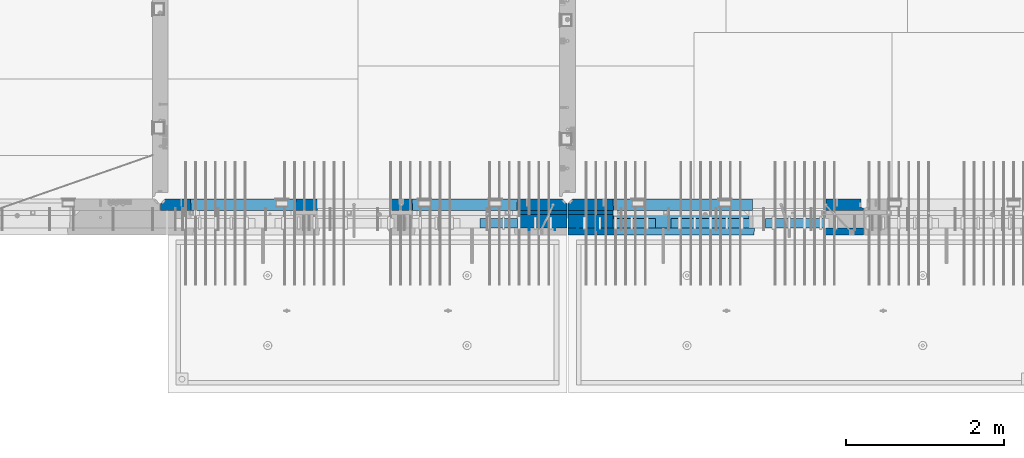
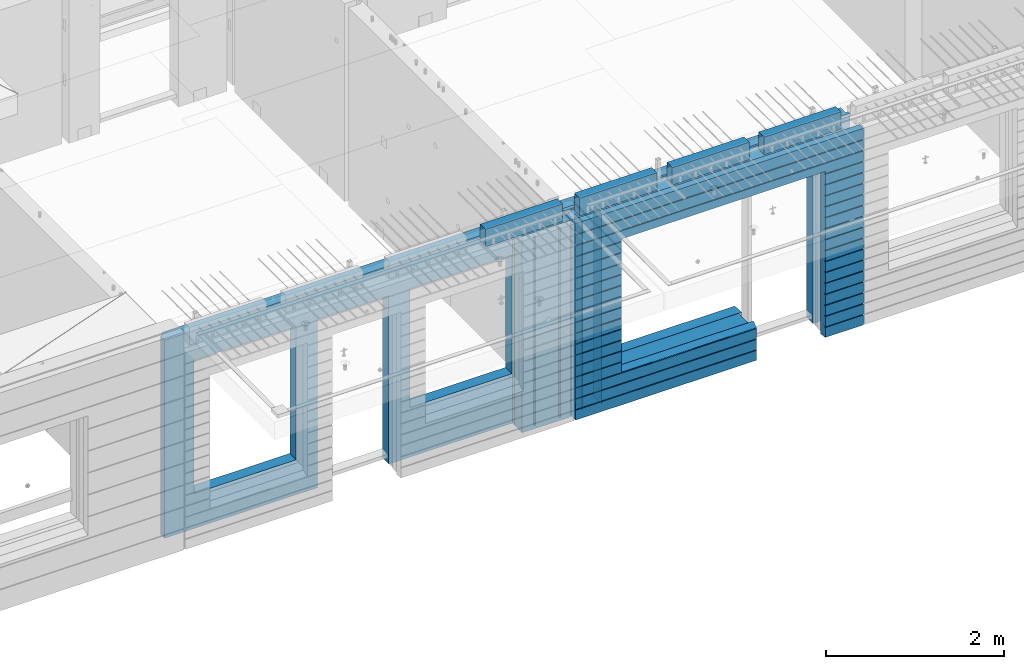
# One storey, part 223 of 341: 16 walls, 8 elements without a shape of their own.
"""IFC2X3 building model written with IfcOpenShell, lengths in millimetres."""

import ifcopenshell
import ifcopenshell.guid

model = None  # the IFC model being written
_history = None  # IfcOwnerHistory: only IFC2X3 demands one
_inside = {}  # id of a spatial element -> (the spatial element, [elements in it])
_under = {}  # id of a project, library or spatial element -> (it, [spatial elements below it])
_declared = {}  # id of a project -> (the project, [libraries it declares])
_typed = {}  # id of a type object -> (the type object, [elements of that type])
_made_of = {}  # id of a material, layer set ... -> (it, [elements and type objects made of it])


def new_model(schema):
    """Start an empty IFC model of exactly this schema.

    Asked for "IFC4X3", IfcOpenShell would pick the latest addendum, in which some entities
    have other attributes; the version numbers below select the first issue.
    IFC2X3 requires an IfcOwnerHistory on every rooted entity: one is made here for all.
    """
    global model, _history
    if schema == "IFC4X3":
        model = ifcopenshell.file(schema_version=(4, 3, 0, 0))
    else:
        model = ifcopenshell.file(schema=schema)
    _inside.clear()
    _under.clear()
    _declared.clear()
    _typed.clear()
    _made_of.clear()
    _history = None
    if model.schema == "IFC2X3":
        org = make("IfcOrganization", Name="unknown")
        user = make(
            "IfcPersonAndOrganization",
            ThePerson=make("IfcPerson", FamilyName="unknown"),
            TheOrganization=org,
        )
        app = make(
            "IfcApplication",
            ApplicationDeveloper=org,
            Version="unknown",
            ApplicationFullName="unknown",
            ApplicationIdentifier="unknown",
        )
        _history = make(
            "IfcOwnerHistory",
            OwningUser=user,
            OwningApplication=app,
            ChangeAction="ADDED",
            CreationDate=0,
        )
    return model


def make(cls, **values):
    """One entity of the class cls with the attributes given. An attribute that is None is left unset."""
    return model.create_entity(
        cls, **{name: value for name, value in values.items() if value is not None}
    )


def rooted(cls, **values):
    """An entity with a GlobalId (a new one), such as an element, a storey or a relation."""
    return make(cls, GlobalId=ifcopenshell.guid.new(), OwnerHistory=_history, **values)


def si_unit(unit_type, name, prefix=None):
    """IfcSIUnit, for example si_unit("LENGTHUNIT", "METRE", prefix="MILLI")."""
    return make("IfcSIUnit", UnitType=unit_type, Prefix=prefix, Name=name)


def assignment(units):
    """IfcUnitAssignment: the units of a project."""
    return None if units is None else make("IfcUnitAssignment", Units=units)


def point(xyz):
    """IfcCartesianPoint."""
    return None if xyz is None else make("IfcCartesianPoint", Coordinates=xyz)


def direction(xyz):
    """IfcDirection."""
    return None if xyz is None else make("IfcDirection", DirectionRatios=xyz)


def frame(location, z_axis=None, x_axis=None):
    """IfcAxis2Placement3D, a coordinate frame: its origin and axes. An axis left out is left unset."""
    return make(
        "IfcAxis2Placement3D",
        Location=point(location),
        Axis=direction(z_axis),
        RefDirection=direction(x_axis),
    )


def origin_with_axes():
    """The frame at (0, 0, 0) with the z axis (0, 0, 1) and the x axis (1, 0, 0) written out."""
    return frame((0.0, 0.0, 0.0), z_axis=(0.0, 0.0, 1.0), x_axis=(1.0, 0.0, 0.0))


def place(relative_to, where):
    """IfcLocalPlacement: puts the frame where relative to a parent placement (None: the world)."""
    return make(
        "IfcLocalPlacement", PlacementRelTo=relative_to, RelativePlacement=where
    )


def context(
    kind, dimensions, precision=None, world=None, true_north=None, identifier=None
):
    """IfcGeometricRepresentationContext, for example the 3D "Model" context."""
    return make(
        "IfcGeometricRepresentationContext",
        ContextIdentifier=identifier,
        ContextType=kind,
        CoordinateSpaceDimension=dimensions,
        Precision=precision,
        WorldCoordinateSystem=world,
        TrueNorth=true_north,
    )


def subcontext(parent, identifier, kind, view, scale=None):
    """IfcGeometricRepresentationSubContext, for example "Body" below "Model"."""
    return make(
        "IfcGeometricRepresentationSubContext",
        ContextIdentifier=identifier,
        ContextType=kind,
        ParentContext=parent,
        TargetScale=scale,
        TargetView=view,
    )


def project(units=None, contexts=None):
    """IfcProject with its units and contexts."""
    return rooted(
        "IfcProject",
        Name="project",
        RepresentationContexts=contexts,
        UnitsInContext=assignment(units),
    )


def spatial(cls, under=None, at=None, **own):
    """A site, building, storey or space (cls), placed at a placement, below another one or the project."""
    s = rooted(cls, ObjectPlacement=at, **own)
    if under is not None:
        _under.setdefault(under.id(), (under, []))[1].append(s)
    return s


def faces_of(points, faces, orient=None, outer=None):
    """IfcFace entities. A face is a list of loops; a loop is a list of indices into points, from 0.

    orient and outer hold one flag for each loop. By default every Orientation is true, the
    first loop of a face is its IfcFaceOuterBound and the others are IfcFaceBound.
    """
    made = []
    for i, loops in enumerate(faces):
        bounds = []
        for j, loop in enumerate(loops):
            is_outer = j == 0 if outer is None else outer[i][j]
            bounds.append(
                make(
                    "IfcFaceOuterBound" if is_outer else "IfcFaceBound",
                    Bound=make("IfcPolyLoop", Polygon=[points[k] for k in loop]),
                    Orientation=True if orient is None else orient[i][j],
                )
            )
        made.append(make("IfcFace", Bounds=bounds))
    return made


def faceted_brep(points, faces, orient=None, outer=None, voids=None):
    """IfcFacetedBrep: a solid bounded by flat faces; with voids (closed shells), ...WithVoids."""
    shared = [point(p) for p in points]
    hull = make("IfcClosedShell", CfsFaces=faces_of(shared, faces, orient, outer))
    if voids is None:
        return make("IfcFacetedBrep", Outer=hull)
    return make(
        "IfcFacetedBrepWithVoids",
        Outer=hull,
        Voids=[
            make(cls, CfsFaces=faces_of(shared, fs, o, b)) for cls, fs, o, b in voids
        ],
    )


def shape(context_of_items, identifier, shape_type, items):
    """IfcShapeRepresentation: the items that make up one representation, for example the "Body"."""
    return make(
        "IfcShapeRepresentation",
        ContextOfItems=context_of_items,
        RepresentationIdentifier=identifier,
        RepresentationType=shape_type,
        Items=items,
    )


def material(Name=None, Category=None):
    """IfcMaterial."""
    return make("IfcMaterial", Name=Name, Category=Category)


def made_of(thing, what):
    """Note that an element or type object is made of a material, layer set ...; save() writes the relation."""
    if what is not None:
        _made_of.setdefault(what.id(), (what, []))[1].append(thing)
    return thing


def type_object(cls, material=None, **own):
    """A type object (cls), such as IfcWallType, which elements share."""
    return made_of(rooted(cls, **own), material)


def element(
    cls,
    number,
    at=None,
    inside=None,
    cuts=None,
    type_object=None,
    material=None,
    context=None,
    identifier="Body",
    shape_type=None,
    held_by="IfcProductDefinitionShape",
    body=None,
    shapes=None,
    **own,
):
    """One element of the class cls, such as IfcWall. Its Tag is "e" and its number.

    at: its placement. inside: the storey or other place that contains it. cuts: it is an
    opening in that element (IfcRelVoidsElement). A single representation is given by context,
    identifier, shape_type and body (its items); several are given by shapes. held_by: the class
    of the entity that holds the representations. save() writes the other relations.
    """
    e = rooted(cls, Tag="e%d" % number, ObjectPlacement=at, **own)
    if body is not None:
        shapes = [shape(context, identifier, shape_type, body)]
    if shapes is not None:
        e.Representation = make(held_by, Representations=shapes)
    if inside is not None:
        _inside.setdefault(inside.id(), (inside, []))[1].append(e)
    if cuts is not None:
        rooted(
            "IfcRelVoidsElement", RelatingBuildingElement=cuts, RelatedOpeningElement=e
        )
    if type_object is not None:
        _typed.setdefault(type_object.id(), (type_object, []))[1].append(e)
    return made_of(e, material)


def aggregate(whole, parts):
    """IfcRelAggregates: a whole, such as a stair, and the parts it consists of."""
    return rooted("IfcRelAggregates", RelatingObject=whole, RelatedObjects=parts)


def save(model, path):
    """Write the relations noted so far, then the file.

    IfcRelAggregates (storeys below a building ...), IfcRelContainedInSpatialStructure (elements
    in a storey), IfcRelDefinesByType, IfcRelAssociatesMaterial and IfcRelDeclares: one each for
    every whole, place, type object, material and project.
    """
    for whole, parts in _under.values():
        aggregate(whole, parts)
    for where, things in _inside.values():
        rooted(
            "IfcRelContainedInSpatialStructure",
            RelatedElements=things,
            RelatingStructure=where,
        )
    for kind, things in _typed.values():
        rooted("IfcRelDefinesByType", RelatedObjects=things, RelatingType=kind)
    for what, things in _made_of.values():
        rooted("IfcRelAssociatesMaterial", RelatedObjects=things, RelatingMaterial=what)
    for by, libraries in _declared.values():
        rooted("IfcRelDeclares", RelatingContext=by, RelatedDefinitions=libraries)
    model.write(path)


model = new_model("IFC2X3")

# Units and contexts
model_context = context("Model", 3, precision=1e-05, world=origin_with_axes())
body_context = subcontext(model_context, "Body", "Model", "MODEL_VIEW")
ifc_project = project(units=[si_unit("LENGTHUNIT", "METRE", prefix="MILLI"), si_unit("AREAUNIT", "SQUARE_METRE"), si_unit("VOLUMEUNIT", "CUBIC_METRE"), si_unit("MASSUNIT", "GRAM", prefix="KILO"), si_unit("TIMEUNIT", "SECOND"), si_unit("PLANEANGLEUNIT", "RADIAN"), si_unit("SOLIDANGLEUNIT", "STERADIAN"), si_unit("THERMODYNAMICTEMPERATUREUNIT", "DEGREE_CELSIUS"), si_unit("LUMINOUSINTENSITYUNIT", "LUMEN")], contexts=[model_context])

# Site, building, storey
site_placement = place(None, origin_with_axes())
site = spatial("IfcSite", under=ifc_project, at=site_placement, CompositionType="ELEMENT")
building_placement = place(site_placement, origin_with_axes())
building = spatial("IfcBuilding", under=site, at=building_placement, CompositionType="ELEMENT")
storey_placement = place(building_placement, origin_with_axes())
storey = spatial("IfcBuildingStorey", under=building, at=storey_placement, Name="5", CompositionType="ELEMENT", Elevation=0.0)

# Assembly, walls
assembly_1_placement = place(storey_placement, origin_with_axes())
assembly_1 = element("IfcElementAssembly", 1, at=assembly_1_placement, inside=storey, AssemblyPlace="NOTDEFINED", PredefinedType="REINFORCEMENT_UNIT")
ifc_material_1 = material(Name="Undefined")
wall_type_1 = type_object("IfcWallType", PredefinedType="NOTDEFINED")
wall_1_placement = place(assembly_1_placement, frame((21325.0, 7780.0, 95115.0), z_axis=(0.0, 0.0, 1.0), x_axis=(0.0, -1.0, 0.0)))
wall_1 = element("IfcWall", 2, at=wall_1_placement, type_object=wall_type_1, material=ifc_material_1, Name="(PD)", context=body_context, shape_type="Brep", body=[
    faceted_brep([(0.0, 5.0, -1300.0), (0.0, 5.0, 1300.0), (180.0, 5.0, 1300.0), (180.0, 5.0, -1300.0), (0.0, -5.0, 1300.0), (180.0, -5.0, 1300.0), (0.0, -5.0, -1300.0), (180.0, -5.0, -1300.0)], [[[0, 1, 2, 3]], [[1, 4, 5, 2]], [[4, 6, 7, 5]], [[6, 0, 3, 7]], [[5, 7, 3, 2]], [[6, 4, 1, 0]]]),
])
wall_2_placement = place(assembly_1_placement, frame((21650.0, 7780.0, 95115.0), z_axis=(0.0, 0.0, 1.0), x_axis=(0.0, -1.0, 0.0)))
wall_2 = element("IfcWall", 3, at=wall_2_placement, type_object=wall_type_1, material=ifc_material_1, Name="(PD)", context=body_context, shape_type="Brep", body=[
    faceted_brep([(0.0, 5.0, -1300.0), (0.0, 5.0, 1300.0), (180.0, 5.0, 1300.0), (180.0, 5.0, -1300.0), (0.0, -5.0, 1300.0), (180.0, -5.0, 1300.0), (0.0, -5.0, -1300.0), (180.0, -5.0, -1300.0)], [[[0, 1, 2, 3]], [[1, 4, 5, 2]], [[4, 6, 7, 5]], [[6, 0, 3, 7]], [[5, 7, 3, 2]], [[6, 4, 1, 0]]]),
])

assembly_2_placement = place(storey_placement, origin_with_axes())
assembly_2 = element("IfcElementAssembly", 4, at=assembly_2_placement, inside=storey, AssemblyPlace="NOTDEFINED", PredefinedType="REINFORCEMENT_UNIT")
wall_3_placement = place(assembly_2_placement, frame((22190.0, 7780.0, 95115.0), z_axis=(0.0, 0.0, 1.0), x_axis=(0.0, -1.0, 0.0)))
wall_3 = element("IfcWall", 5, at=wall_3_placement, type_object=wall_type_1, material=ifc_material_1, Name="(PD)", context=body_context, shape_type="Brep", body=[
    faceted_brep([(0.0, 5.0, -1300.0), (0.0, 5.0, 1300.0), (180.0, 5.0, 1300.0), (180.0, 5.0, -1300.0), (0.0, -5.0, 1300.0), (180.0, -5.0, 1300.0), (0.0, -5.0, -1300.0), (180.0, -5.0, -1300.0)], [[[0, 1, 2, 3]], [[1, 4, 5, 2]], [[4, 6, 7, 5]], [[6, 0, 3, 7]], [[5, 7, 3, 2]], [[6, 4, 1, 0]]]),
])
wall_4_placement = place(assembly_2_placement, frame((21940.0, 7780.0, 95115.0), z_axis=(0.0, 0.0, 1.0), x_axis=(0.0, -1.0, 0.0)))
wall_4 = element("IfcWall", 6, at=wall_4_placement, type_object=wall_type_1, material=ifc_material_1, Name="(PD)", context=body_context, shape_type="Brep", body=[
    faceted_brep([(0.0, 5.0, -1300.0), (0.0, 5.0, 1300.0), (180.0, 5.0, 1300.0), (180.0, 5.0, -1300.0), (0.0, -5.0, 1300.0), (180.0, -5.0, 1300.0), (0.0, -5.0, -1300.0), (180.0, -5.0, -1300.0)], [[[0, 1, 2, 3]], [[1, 4, 5, 2]], [[4, 6, 7, 5]], [[6, 0, 3, 7]], [[5, 7, 3, 2]], [[6, 4, 1, 0]]]),
])

# Assemblies, wall
assembly_3_placement = place(storey_placement, origin_with_axes())
assembly_3 = element("IfcElementAssembly", 7, at=assembly_3_placement, inside=storey, AssemblyPlace="NOTDEFINED", PredefinedType="REINFORCEMENT_UNIT")
assembly_4_placement = place(assembly_3_placement, origin_with_axes())
assembly_4 = element("IfcElementAssembly", 8, at=assembly_4_placement, Name="Steel Assembly", AssemblyPlace="NOTDEFINED", PredefinedType="NOTDEFINED")
aggregate(assembly_3, [assembly_4])
ifc_material_2 = material()
wall_type_2 = type_object("IfcWallType", PredefinedType="NOTDEFINED")
wall_5_placement = place(assembly_4_placement, frame((20699.9998568133, 7690.00021946163, 96590.0), z_axis=(0.0, 0.0, 1.0), x_axis=(1.0, 0.0, 0.0)))
wall_5 = element("IfcWall", 9, at=wall_5_placement, type_object=wall_type_2, material=ifc_material_2, context=body_context, shape_type="Brep", body=[
    faceted_brep([(0.0, 60.0, -120.0), (0.0, 60.0, 120.0), (1000.0, 60.0, 120.0), (1000.0, 60.0, -120.0), (0.0, -60.0, 120.0), (1000.0, -60.0, 120.0), (0.0, -60.0, -120.0), (1000.0, -60.0, -120.0)], [[[0, 1, 2, 3]], [[1, 4, 5, 2]], [[4, 6, 7, 5]], [[6, 0, 3, 7]], [[5, 7, 3, 2]], [[6, 4, 1, 0]]]),
])
aggregate(assembly_4, [wall_5])

# Assemblies, walls
assembly_5_placement = place(storey_placement, origin_with_axes())
assembly_5 = element("IfcElementAssembly", 10, at=assembly_5_placement, inside=storey, AssemblyPlace="NOTDEFINED", PredefinedType="REINFORCEMENT_UNIT")
assembly_6_placement = place(assembly_5_placement, origin_with_axes())
assembly_6 = element("IfcElementAssembly", 11, at=assembly_6_placement, Name="Steel Assembly", AssemblyPlace="NOTDEFINED", PredefinedType="NOTDEFINED")
wall_6_placement = place(assembly_6_placement, frame((24309.9998568133, 7690.00021946163, 96590.0), z_axis=(0.0, 0.0, 1.0), x_axis=(1.0, 0.0, 0.0)))
wall_6 = element("IfcWall", 12, at=wall_6_placement, type_object=wall_type_2, material=ifc_material_2, context=body_context, shape_type="Brep", body=[
    faceted_brep([(0.0, 60.0, -120.0), (0.0, 60.0, 120.0), (1000.0, 60.0, 120.0), (1000.0, 60.0, -120.0), (0.0, -60.0, 120.0), (1000.0, -60.0, 120.0), (0.0, -60.0, -120.0), (1000.0, -60.0, -120.0)], [[[0, 1, 2, 3]], [[1, 4, 5, 2]], [[4, 6, 7, 5]], [[6, 0, 3, 7]], [[5, 7, 3, 2]], [[6, 4, 1, 0]]]),
])
aggregate(assembly_6, [wall_6])
assembly_7_placement = place(assembly_5_placement, origin_with_axes())
assembly_7 = element("IfcElementAssembly", 13, at=assembly_7_placement, Name="Steel Assembly", AssemblyPlace="NOTDEFINED", PredefinedType="NOTDEFINED")
wall_7_placement = place(assembly_7_placement, frame((23119.9998568133, 7690.00021946163, 96590.0), z_axis=(0.0, 0.0, 1.0), x_axis=(1.0, 0.0, 0.0)))
wall_7 = element("IfcWall", 14, at=wall_7_placement, type_object=wall_type_2, material=ifc_material_2, context=body_context, shape_type="Brep", body=[
    faceted_brep([(0.0, 60.0, -120.0), (0.0, 60.0, 120.0), (1000.0, 60.0, 120.0), (1000.0, 60.0, -120.0), (0.0, -60.0, 120.0), (1000.0, -60.0, 120.0), (0.0, -60.0, -120.0), (1000.0, -60.0, -120.0)], [[[0, 1, 2, 3]], [[1, 4, 5, 2]], [[4, 6, 7, 5]], [[6, 0, 3, 7]], [[5, 7, 3, 2]], [[6, 4, 1, 0]]]),
])
aggregate(assembly_7, [wall_7])
assembly_8_placement = place(assembly_5_placement, origin_with_axes())
assembly_8 = element("IfcElementAssembly", 15, at=assembly_8_placement, Name="Steel Assembly", AssemblyPlace="NOTDEFINED", PredefinedType="NOTDEFINED")
aggregate(assembly_5, [assembly_8, assembly_7, assembly_6])
wall_8_placement = place(assembly_8_placement, frame((21919.9998568133, 7690.00021946163, 96590.0), z_axis=(0.0, 0.0, 1.0), x_axis=(1.0, 0.0, 0.0)))
wall_8 = element("IfcWall", 16, at=wall_8_placement, type_object=wall_type_2, material=ifc_material_2, context=body_context, shape_type="Brep", body=[
    faceted_brep([(0.0, 60.0, -120.0), (0.0, 60.0, 120.0), (1000.0, 60.0, 120.0), (1000.0, 60.0, -120.0), (0.0, -60.0, 120.0), (1000.0, -60.0, 120.0), (0.0, -60.0, -120.0), (1000.0, -60.0, -120.0)], [[[0, 1, 2, 3]], [[1, 4, 5, 2]], [[4, 6, 7, 5]], [[6, 0, 3, 7]], [[5, 7, 3, 2]], [[6, 4, 1, 0]]]),
])
aggregate(assembly_8, [wall_8])

# Wall
ifc_material_3 = material(Name="CONCRETE/C35/45")
wall_type_3 = type_object("IfcWallType", PredefinedType="NOTDEFINED")
wall_9_placement = place(assembly_1_placement, frame((21810.0, 7925.0, 95112.5), z_axis=(0.0, 0.0, 1.0), x_axis=(-1.0, 3.00000001838171e-08, 0.0)))
wall_9 = element("IfcWall", 17, at=wall_9_placement, type_object=wall_type_3, material=ifc_material_3, context=body_context, shape_type="Brep", body=[
    faceted_brep([(5145.0, 75.0, -1357.5), (5145.0, -15.0, -1357.5), (5085.0, -75.0, -1357.5), (3165.00051719707, -75.0, -1357.5), (3161.15436335092, 75.0, -1357.5), (5085.0, -75.0, 1357.5), (5145.0, -15.0, 1357.5), (5145.0, 75.0, 1357.5), (10.0, 75.0, 1357.5), (10.0, -15.0, 1357.5), (70.0, -75.0, 1357.5), (10.0, -15.0, -1357.5), (70.0, -75.0, -1357.5), (10.0, 75.0, -1357.5), (2238.84667104322, 75.0, -1357.5), (2235.00051719707, -75.0, -1357.5), (2238.84667104322, 75.0, 948.653846153844), (2235.00051719707, -75.0, 952.5), (635.00013572734, -75.0, -682.5), (639.054189781393, 75.0, -678.445945945947), (639.054189781393, 75.0, 948.445945945947), (635.00013572734, -75.0, 952.5), (1965.00013572734, -75.0, -682.5), (1960.94608167329, 75.0, -678.445945945947), (1965.00013572734, -75.0, 952.5), (1960.94608167329, 75.0, 948.445945945947), (4764.99937278789, -75.0, -882.5), (4760.94531873383, 75.0, -878.445945945947), (3439.05342684194, 75.0, -878.445945945947), (3434.99937278789, -75.0, -882.5), (3165.00051719707, -75.0, 952.5), (3434.99937278789, -75.0, 952.5), (4764.99937278789, -75.0, 952.5), (4760.94531873383, 75.0, 948.445945945947), (3439.05342684194, 75.0, 948.445945945947), (3161.15436335092, 75.0, 948.653846153844)], [[[0, 1, 2, 3, 4]], [[5, 2, 1, 6]], [[0, 7, 6, 1]], [[5, 6, 7, 8, 9, 10]], [[9, 11, 12, 10]], [[8, 13, 11, 9]], [[12, 11, 13, 14, 15]], [[15, 14, 16, 17]], [[18, 19, 20, 21]], [[22, 23, 19, 18]], [[23, 22, 24, 25]], [[21, 20, 25, 24]], [[26, 27, 28, 29]], [[3, 2, 5, 10, 12, 15, 17, 30], [26, 29, 31, 32], [22, 18, 21, 24]], [[27, 26, 32, 33]], [[31, 34, 33, 32]], [[29, 28, 34, 31]], [[13, 8, 7, 0, 4, 35, 16, 14], [27, 33, 34, 28], [23, 25, 20, 19]], [[17, 16, 35, 30]], [[4, 3, 30, 35]]]),
])

wall_10_placement = place(assembly_2_placement, frame((25550.0, 7925.0, 95112.5), z_axis=(0.0, 0.0, 1.0), x_axis=(-1.0, 3.00000001838171e-08, 0.0)))
wall_10 = element("IfcWall", 18, at=wall_10_placement, type_object=wall_type_3, material=ifc_material_3, context=body_context, shape_type="Brep", body=[
    faceted_brep([(0.0, 75.0, 1357.5), (0.0, 75.0, -1357.5), (0.0, 45.0, -1357.5), (0.0, 45.0, 1357.5), (475.000517197066, -75.0, -1357.5), (478.846671043222, 75.0, -1357.5), (478.846671043219, 75.0, 948.653846153844), (475.000517197066, -75.0, 952.5), (32.5, -75.0, -1357.5), (32.5, 32.0, -1357.5), (32.5, -75.0, 1357.5), (32.5, 32.0, 1357.5), (3675.0, -75.0, 1357.5), (3735.0, -15.0, 1357.5), (3735.0, 75.0, 1357.5), (3735.0, 75.0, -1357.5), (3735.0, -15.0, -1357.5), (3675.0, -75.0, -1357.5), (1405.00051719707, -75.0, -1357.5), (1401.15436335091, 75.0, -1357.5), (1405.00051719707, -75.0, -882.5), (1401.15436335091, 75.0, -878.445945945947), (1334.05403802673, 75.0, 948.653846153844), (3160.9460816706, 75.0, -878.445945945947), (3160.9460816706, 75.0, 948.445945945947), (1401.15436335091, 75.0, 948.653846153844), (1330.00013572465, -75.0, 952.5), (1405.00051719707, -75.0, 952.5), (3165.00013572465, -75.0, -882.5), (3165.00013572465, -75.0, 952.5)], [[[0, 1, 2, 3]], [[4, 5, 6, 7]], [[8, 9, 2, 1, 5, 4]], [[10, 11, 9, 8]], [[3, 2, 9, 11]], [[10, 12, 13, 14, 0, 3, 11]], [[15, 14, 13, 16]], [[12, 17, 16, 13]], [[15, 16, 17, 18, 19]], [[19, 18, 20, 21]], [[22, 6, 5, 1, 0, 14, 15, 19, 21, 23, 24, 25]], [[26, 7, 6, 22, 25, 27]], [[28, 20, 18, 17, 12, 10, 8, 4, 7, 26, 27, 29]], [[25, 24, 29, 27]], [[23, 28, 29, 24]], [[21, 20, 28, 23]]]),
])

wall_type_4 = type_object("IfcWallType", PredefinedType="NOTDEFINED")
wall_11_placement = place(assembly_1_placement, frame((21800.0000381475, 7825.0, 95112.5), z_axis=(0.0, 0.0, 1.0), x_axis=(-1.0, 3.00000001838171e-08, 0.0)))
wall_11 = element("IfcWall", 19, at=wall_11_placement, type_object=wall_type_4, material=ifc_material_3, context=body_context, shape_type="Brep", body=[
    faceted_brep([(0.0, 25.0, -1357.5), (0.0, 25.0, 1357.5), (625.001908754726, 25.0, 1357.5), (625.001908754726, 25.0, -1357.5), (0.0, -25.0, 1357.5), (625.001908754726, -25.0, 1357.5), (0.0, -25.0, -1357.5), (625.001908754726, -25.0, -1357.5)], [[[0, 1, 2, 3]], [[1, 4, 5, 2]], [[4, 6, 7, 5]], [[6, 0, 3, 7]], [[5, 7, 3, 2]], [[6, 4, 1, 0]]]),
])

wall_12_placement = place(assembly_2_placement, frame((22385.0000381475, 7825.00011629906, 95112.5), z_axis=(0.0, 0.0, 1.0), x_axis=(-1.0, 3.00000001838171e-08, 0.0)))
wall_12 = element("IfcWall", 20, at=wall_12_placement, type_object=wall_type_4, material=ifc_material_3, context=body_context, shape_type="Brep", body=[
    faceted_brep([(0.0, 25.0, -1357.5), (0.0, 25.0, 1357.5), (570.001908754726, 25.0, 1357.5), (570.001908754726, 25.0, -1357.5), (0.0, -25.0, 1357.5), (570.001908754726, -25.0, 1357.5), (0.0, -25.0, -1357.5), (570.001908754726, -25.0, -1357.5)], [[[0, 1, 2, 3]], [[1, 4, 5, 2]], [[4, 6, 7, 5]], [[6, 0, 3, 7]], [[5, 7, 3, 2]], [[6, 4, 1, 0]]]),
])

ifc_material_4 = material(Name="SPU")
wall_type_5 = type_object("IfcWallType", PredefinedType="NOTDEFINED")
wall_13_placement = place(assembly_1_placement, frame((21800.0000381475, 7715.0, 95102.5), z_axis=(0.0, 0.0, 1.0), x_axis=(-1.0, 3.00000001838171e-08, 0.0)))
wall_13 = element("IfcWall", 21, at=wall_13_placement, type_object=wall_type_5, material=ifc_material_4, context=body_context, shape_type="Brep", body=[
    faceted_brep([(0.0, 85.0, -1347.5), (0.0, 85.0, 1347.5), (625.001908754726, 85.0, 1347.5), (625.001908754726, 85.0, -1347.5), (0.0, -85.0, 1347.5), (625.001908754726, -85.0, 1347.5), (0.0, -85.0, -1347.5), (625.001908754726, -85.0, -1347.5)], [[[0, 1, 2, 3]], [[1, 4, 5, 2]], [[4, 6, 7, 5]], [[6, 0, 3, 7]], [[5, 7, 3, 2]], [[6, 4, 1, 0]]]),
])

aggregate(assembly_1, [wall_13, wall_11, wall_1, wall_2, wall_9])

wall_14_placement = place(assembly_2_placement, frame((22385.0000381475, 7715.00011629906, 95102.5), z_axis=(0.0, 0.0, 1.0), x_axis=(-1.0, 3.00000001838171e-08, 0.0)))
wall_14 = element("IfcWall", 22, at=wall_14_placement, type_object=wall_type_5, material=ifc_material_4, context=body_context, shape_type="Brep", body=[
    faceted_brep([(0.0, 85.0, -1347.5), (0.0, 85.0, 1347.5), (570.001908754726, 85.0, 1347.5), (570.001908754726, 85.0, -1347.5), (0.0, -85.0, 1347.5), (570.001908754726, -85.0, 1347.5), (0.0, -85.0, -1347.5), (570.001908754726, -85.0, -1347.5)], [[[0, 1, 2, 3]], [[1, 4, 5, 2]], [[4, 6, 7, 5]], [[6, 0, 3, 7]], [[5, 7, 3, 2]], [[6, 4, 1, 0]]]),
])

ifc_material_5 = material(Name="CONCRETE/C30/37")
wall_type_6 = type_object("IfcWallType", PredefinedType="NOTDEFINED")
wall_15_placement = place(assembly_2_placement, frame((25550.0, 7587.5, 95102.5), z_axis=(0.0, 0.0, 1.0), x_axis=(-1.0, 3.00000001838171e-08, 0.0)))
wall_15 = element("IfcWall", 23, at=wall_15_placement, type_object=wall_type_6, material=ifc_material_5, context=body_context, shape_type="Brep", body=[
    faceted_brep([(3135.00013572465, 42.5, -912.000000055254), (3135.00013572465, 42.5, -912.5), (3134.8486205936, 41.2121213860491, -911.742424344731), (3735.0, 32.4999991126861, -1049.99999959956), (3735.0, 32.4999992506973, -1060.00000000076), (1383.82179161871, 32.4999992506973, -1060.00000000076), (1383.82179160247, 32.4999991126861, -1049.99999959956), (3735.0, 42.5, -1062.00000005522), (1384.99845837354, 42.5, -1062.00000005522), (3735.0, 42.5, -1198.00000011075), (1384.99845837354, 42.5, -1198.00000011075), (3735.0, 32.4999991121604, -1199.99999959957), (1383.8217916024, 32.4999991121604, -1199.99999959957), (3735.0, 32.4999992501671, -1210.00000000079), (1383.82179161864, 32.4999992501671, -1210.00000000079), (3735.0, 42.5, -1212.00000005524), (1384.99845837354, 42.5, -1212.00000005524), (3735.0, 42.5, -1347.5), (1384.99845837354, 42.5, -1347.5), (3735.0, -42.5, -1347.5), (1374.99679170687, -42.5, -1347.5), (3.63797880709171e-12, 32.4999992499725, 1039.99999999921), (3735.0, 32.4999992499725, 1039.99999999921), (3735.0, 42.5, 1037.99999994476), (0.0, 42.5, 1037.99999994476), (3.63797880709171e-12, 32.4999991119639, 1050.00000040043), (3735.0, 32.4999991119639, 1050.00000040043), (0.0, 42.5, 1051.99999988925), (3735.0, 42.5, 1051.99999988925), (0.0, 42.5, 1187.99999994476), (3735.0, 42.5, 1187.99999994476), (-3.63797880709171e-12, 32.499999249967, 1189.99999999923), (3735.0, 32.499999249967, 1189.99999999923), (-3.63797880709171e-12, 32.4999991119576, 1200.00000040043), (3735.0, 32.4999991119576, 1200.00000040043), (0.0, 42.5, 1201.99999988925), (3735.0, 42.5, 1201.99999988925), (0.0, 42.5, 1347.5), (3735.0, 42.5, 1347.5), (0.0, -42.5, 1347.5), (3735.0, -42.5, 1347.5), (3125.00013572465, -42.5, 927.5), (3125.00013572465, -42.5, -862.5), (1374.99679170687, -42.5, -862.5), (0.0, -42.5, -1347.5), (505.000125040202, -42.5, -1347.5), (505.000125040206, -42.5, 927.5), (505.000125040206, -42.5, 932.502857142856), (1370.00013572465, -42.5, 932.502857142856), (1374.99679170687, -42.5, 932.5), (3125.00013572465, -42.5, 932.5), (0.0, 42.5, -1347.5), (494.998458373539, 42.5, -1347.5), (0.0, 42.5, -1212.00000005524), (494.998458373539, 42.5, -1212.00000005524), (0.0, 32.4999992501671, -1210.00000000079), (496.175125128437, 32.4999992501671, -1210.00000000079), (0.0, 32.4999991121604, -1199.99999959957), (496.175125144673, 32.4999991121604, -1199.99999959957), (0.0, 42.5, -1198.00000011075), (494.998458373539, 42.5, -1198.00000011075), (0.0, 42.5, -1062.00000005522), (494.998458373539, 42.5, -1062.00000005522), (0.0, 32.4999992506973, -1060.00000000076), (496.175125128375, 32.4999992506973, -1060.00000000076), (0.0, 32.4999991126861, -1049.99999959956), (496.175125144611, 32.4999991126861, -1049.99999959956), (0.0, 42.5, -1048.00000011074), (494.998458373539, 42.5, -1048.00000011074), (0.0, 42.5, -912.000000055254), (494.998458373539, 42.5, -912.000000055254), (0.0, 32.4999992512376, -910.000000000786), (496.175125128309, 32.4999992512376, -910.000000000786), (0.0, 32.499999113239, -899.99999959959), (496.175125144546, 32.499999113239, -899.99999959959), (0.0, 42.5, -898.000000110769), (494.998458373539, 42.5, -898.000000110769), (0.0, 42.5, -762.000000055225), (494.998458373539, 42.5, -762.000000055225), (0.0, 32.4999992517696, -760.000000000757), (496.175125128244, 32.4999992517696, -760.000000000757), (0.0, 32.4999991137702, -749.99999959956), (496.175125144484, 32.4999991137702, -749.99999959956), (0.0, 42.5, -748.00000011074), (494.998458373539, 42.5, -748.00000011074), (0.0, 42.5, -612.000000055239), (494.998458373539, 42.5, -612.000000055239), (0.0, 32.4999992522971, -610.000000000771), (496.175125128182, 32.4999992522971, -610.000000000771), (0.0, 32.4999991143004, -599.99999959956), (496.175125144422, 32.4999991143004, -599.99999959956), (0.0, 42.5, -598.000000110755), (494.998458373539, 42.5, -598.000000110755), (0.0, 42.5, -462.000000055239), (494.998458373539, 42.5, -462.000000055239), (0.0, 32.4999992528365, -460.000000000771), (496.17512512812, 32.4999992528365, -460.000000000771), (0.0, 32.4999991148252, -449.999999599575), (496.17512514436, 32.4999991148252, -449.999999599575), (0.0, 42.5, -448.000000110755), (494.998458373539, 42.5, -448.000000110755), (0.0, 42.5, -312.000000055254), (494.998458373539, 42.5, -312.000000055254), (0.0, 32.4999992533649, -310.000000000786), (496.175125128058, 32.4999992533649, -310.000000000786), (0.0, 32.4999991153618, -299.99999959959), (496.175125144298, 32.4999991153618, -299.99999959959), (0.0, 42.5, -298.000000110769), (494.998458373539, 42.5, -298.000000110769), (0.0, 42.5, -162.000000055239), (494.998458373539, 42.5, -162.000000055239), (0.0, 32.4999992538978, -160.000000000757), (496.175125127997, 32.4999992538978, -160.000000000757), (0.0, 32.4999991158993, -149.99999959956), (496.175125144237, 32.4999991158993, -149.99999959956), (0.0, 42.5, -148.000000110755), (494.998458373539, 42.5, -148.000000110755), (0.0, 42.5, -12.0000000552391), (494.998458373539, 42.5, -12.0000000552391), (0.0, 32.4999992538942, -10.0000000007858), (496.175125127997, 32.4999992538942, -10.0000000007858), (3.63797880709171e-12, 32.4999992499852, 889.999999999229), (3.63797880709171e-12, 32.4999991119857, 900.000000400425), (496.175125144691, 32.4999991119857, 900.000000400425), (496.175125128459, 32.4999992499852, 889.999999999229), (0.0, 42.5, 887.999999944761), (494.998458373539, 42.5, 887.999999944761), (0.0, 42.5, 751.999999889245), (494.998458373539, 42.5, 751.999999889245), (0.0, 32.4999991120039, 750.00000040044), (496.175125144691, 32.4999991120039, 750.00000040044), (0.0, 32.4999992499997, 739.999999999229), (496.175125128455, 32.4999992499997, 739.999999999229), (0.0, 42.5, 737.999999944761), (494.998458373539, 42.5, 737.999999944761), (0.0, 42.5, 601.99999988926), (494.998458373539, 42.5, 601.99999988926), (0.0, 32.4999991120094, 600.00000040044), (496.175125144691, 32.4999991120094, 600.00000040044), (0.0, 32.499999250017, 589.999999999229), (496.175125128455, 32.499999250017, 589.999999999229), (0.0, 42.5, 587.999999944775), (494.998458373539, 42.5, 587.999999944775), (0.0, 42.5, 451.999999889231), (494.998458373539, 42.5, 451.999999889231), (0.0, 32.4999991120258, 450.000000400411), (496.175125144688, 32.4999991120258, 450.000000400411), (0.0, 32.4999992500289, 439.999999999214), (496.175125128451, 32.4999992500289, 439.999999999214), (0.0, 42.5, 437.999999944746), (494.998458373539, 42.5, 437.999999944746), (0.0, 42.5, 301.999999889245), (494.998458373539, 42.5, 301.999999889245), (-3.63797880709171e-12, 32.4999991120458, 300.00000040044), (496.175125144688, 32.4999991120458, 300.00000040044), (-3.63797880709171e-12, 32.4999992500416, 289.999999999229), (496.175125128451, 32.4999992500416, 289.999999999229), (0.0, 42.5, 287.999999944761), (494.998458373539, 42.5, 287.999999944761), (0.0, 42.5, 151.99999988926), (494.998458373539, 42.5, 151.99999988926), (0.0, 32.4999991120549, 150.00000040044), (496.175125144684, 32.4999991120549, 150.00000040044), (0.0, 32.4999992500552, 139.999999999229), (496.175125128448, 32.4999992500552, 139.999999999229), (0.0, 42.5, 137.999999944775), (494.998458373539, 42.5, 137.999999944775), (0.0, 42.5, 1.99999988924537), (494.998458373539, 42.5, 1.99999988924537), (0.0, 32.4999991158911, 4.00425051338971e-07), (496.175125144237, 32.4999991158911, 4.00425051338971e-07), (0.0, 42.5, 901.999999889245), (494.998458373539, 42.5, 901.999999889245), (494.998458373539, 42.5, 927.5), (505.000517197066, 42.5, 927.5), (1360.00013572465, 42.5, 927.5), (1370.00013572465, 42.5, 927.5), (1375.00051719707, 42.5, 927.5), (1384.99845837354, 42.5, 927.5), (3125.00013572465, 42.5, 927.5), (3135.00013572465, 42.5, 927.5), (3735.0, 42.5, 901.999999889245), (3135.00013572465, 42.5, 901.999999889245), (3735.0, 32.4999991119857, 900.000000400425), (3133.82366503195, 32.4999991119857, 900.000000400425), (3735.0, 32.4999992499852, 889.999999999229), (3133.82366504818, 32.4999992499852, 889.999999999229), (3735.0, 42.5, 887.999999944761), (3135.00013572465, 42.5, 887.999999944761), (3735.0, 42.5, 751.999999889245), (3135.00013572465, 42.5, 751.999999889245), (3735.0, 32.4999991120039, 750.00000040044), (3133.82366503195, 32.4999991120039, 750.00000040044), (3735.0, 32.4999992499997, 739.999999999229), (3133.82366504818, 32.4999992499997, 739.999999999229), (3735.0, 42.5, 737.999999944761), (3135.00013572465, 42.5, 737.999999944761), (3735.0, 42.5, 601.99999988926), (3135.00013572465, 42.5, 601.99999988926), (3735.0, 32.4999991120094, 600.00000040044), (3133.82366503195, 32.4999991120094, 600.00000040044), (3735.0, 32.499999250017, 589.999999999229), (3133.82366504818, 32.499999250017, 589.999999999229), (3735.0, 42.5, 587.999999944775), (3135.00013572465, 42.5, 587.999999944775), (3735.0, 42.5, 451.999999889231), (3135.00013572465, 42.5, 451.999999889231), (3735.0, 32.4999991120258, 450.000000400411), (3133.82366503195, 32.4999991120258, 450.000000400411), (3735.0, 32.4999992500289, 439.999999999214), (3133.82366504818, 32.4999992500289, 439.999999999214), (3735.0, 42.5, 437.999999944746), (3135.00013572465, 42.5, 437.999999944746), (3735.0, 42.5, 301.999999889245), (3135.00013572465, 42.5, 301.999999889245), (3735.0, 32.4999991120458, 300.00000040044), (3133.82366503195, 32.4999991120458, 300.00000040044), (3735.0, 32.4999992500416, 289.999999999229), (3133.82366504819, 32.4999992500416, 289.999999999229), (3735.0, 42.5, 287.999999944761), (3135.00013572465, 42.5, 287.999999944761), (3735.0, 42.5, 151.99999988926), (3135.00013572465, 42.5, 151.99999988926), (3735.0, 32.4999991120549, 150.00000040044), (3133.82366503195, 32.4999991120549, 150.00000040044), (3735.0, 32.4999992500552, 139.999999999229), (3133.82366504819, 32.4999992500552, 139.999999999229), (3735.0, 42.5, 137.999999944775), (3135.00013572465, 42.5, 137.999999944775), (3735.0, 42.5, 1.99999988924537), (3135.00013572465, 42.5, 1.99999988924537), (3735.0, 32.4999991158911, 4.00425051338971e-07), (3735.0, 32.4999992538942, -10.0000000007858), (3133.82366504864, 32.4999992538942, -10.0000000007858), (3133.8236650324, 32.4999991158911, 4.00425051338971e-07), (3735.0, 42.5, -12.0000000552391), (3135.00013572465, 42.5, -12.0000000552391), (3735.0, 42.5, -148.000000110755), (3135.00013572465, 42.5, -148.000000110755), (3735.0, 32.4999991158993, -149.99999959956), (3133.8236650324, 32.4999991158993, -149.99999959956), (3735.0, 32.4999992538978, -160.000000000757), (3133.82366504864, 32.4999992538978, -160.000000000757), (3735.0, 42.5, -162.000000055239), (3135.00013572465, 42.5, -162.000000055239), (3735.0, 42.5, -298.000000110769), (3135.00013572465, 42.5, -298.000000110769), (3735.0, 32.4999991153618, -299.99999959959), (3133.82366503234, 32.4999991153618, -299.99999959959), (3735.0, 32.4999992533649, -310.000000000786), (3133.82366504858, 32.4999992533649, -310.000000000786), (3735.0, 42.5, -312.000000055254), (3135.00013572465, 42.5, -312.000000055254), (3735.0, 42.5, -448.000000110755), (3135.00013572465, 42.5, -448.000000110755), (3735.0, 32.4999991148252, -449.999999599575), (3133.82366503228, 32.4999991148252, -449.999999599575), (3735.0, 32.4999992528365, -460.000000000771), (3133.82366504852, 32.4999992528365, -460.000000000771), (3735.0, 42.5, -462.000000055239), (3135.00013572465, 42.5, -462.000000055239), (3735.0, 42.5, -598.000000110755), (3135.00013572465, 42.5, -598.000000110755), (3735.0, 32.4999991143004, -599.99999959956), (3133.82366503222, 32.4999991143004, -599.99999959956), (3735.0, 32.4999992522971, -610.000000000771), (3133.82366504845, 32.4999992522971, -610.000000000771), (3735.0, 42.5, -612.000000055239), (3135.00013572465, 42.5, -612.000000055239), (3735.0, 42.5, -748.00000011074), (3135.00013572465, 42.5, -748.00000011074), (3735.0, 32.4999991137702, -749.99999959956), (3133.82366503216, 32.4999991137702, -749.99999959956), (3735.0, 32.4999992517696, -760.000000000757), (3133.82366504839, 32.4999992517696, -760.000000000757), (3735.0, 42.5, -762.000000055225), (3135.00013572465, 42.5, -762.000000055225), (3735.0, 42.5, -898.000000110769), (3135.00013572465, 42.5, -898.000000110769), (3735.0, 32.499999113239, -899.99999959959), (3133.82366503209, 32.499999113239, -899.99999959959), (3133.82366504284, 32.4999992045623, -906.617646590923), (3735.0, 42.5, -1048.00000011074), (3735.0, 42.5, -912.000000055254), (3735.0, 32.4999992512376, -910.000000000786), (1384.99845837354, 42.5, -1048.00000011074), (1384.99845837354, 42.5, -912.5), (1384.84691798997, 41.2121213860719, -911.742424344746), (1383.82179161877, 32.4999992512376, -910.000000000786), (1383.82179161327, 32.4999992045614, -906.617646590908)], [[[0, 1, 2]], [[3, 4, 5, 6]], [[4, 7, 8, 5]], [[7, 9, 10, 8]], [[9, 11, 12, 10]], [[11, 13, 14, 12]], [[13, 15, 16, 14]], [[15, 17, 18, 16]], [[17, 19, 20, 18]], [[21, 22, 23, 24]], [[25, 26, 22, 21]], [[27, 28, 26, 25]], [[28, 27, 29, 30]], [[31, 32, 30, 29]], [[33, 34, 32, 31]], [[35, 36, 34, 33]], [[37, 38, 36, 35]], [[37, 39, 40, 38]], [[41, 42, 43, 20, 19, 40, 39, 44, 45, 46, 47, 48, 49, 50]], [[44, 51, 52, 45]], [[51, 53, 54, 52]], [[53, 55, 56, 54]], [[55, 57, 58, 56]], [[57, 59, 60, 58]], [[59, 61, 62, 60]], [[61, 63, 64, 62]], [[63, 65, 66, 64]], [[65, 67, 68, 66]], [[67, 69, 70, 68]], [[69, 71, 72, 70]], [[71, 73, 74, 72]], [[73, 75, 76, 74]], [[75, 77, 78, 76]], [[77, 79, 80, 78]], [[79, 81, 82, 80]], [[81, 83, 84, 82]], [[83, 85, 86, 84]], [[85, 87, 88, 86]], [[87, 89, 90, 88]], [[89, 91, 92, 90]], [[91, 93, 94, 92]], [[93, 95, 96, 94]], [[95, 97, 98, 96]], [[97, 99, 100, 98]], [[99, 101, 102, 100]], [[101, 103, 104, 102]], [[103, 105, 106, 104]], [[105, 107, 108, 106]], [[107, 109, 110, 108]], [[109, 111, 112, 110]], [[111, 113, 114, 112]], [[113, 115, 116, 114]], [[115, 117, 118, 116]], [[117, 119, 120, 118]], [[121, 122, 123, 124]], [[125, 121, 124, 126]], [[127, 125, 126, 128]], [[129, 127, 128, 130]], [[131, 129, 130, 132]], [[133, 131, 132, 134]], [[135, 133, 134, 136]], [[137, 135, 136, 138]], [[139, 137, 138, 140]], [[141, 139, 140, 142]], [[143, 141, 142, 144]], [[145, 143, 144, 146]], [[147, 145, 146, 148]], [[149, 147, 148, 150]], [[151, 149, 150, 152]], [[153, 151, 152, 154]], [[155, 153, 154, 156]], [[157, 155, 156, 158]], [[159, 157, 158, 160]], [[161, 159, 160, 162]], [[163, 161, 162, 164]], [[165, 163, 164, 166]], [[167, 165, 166, 168]], [[169, 167, 168, 170]], [[119, 169, 170, 120]], [[117, 115, 113, 111, 109, 107, 105, 103, 101, 99, 97, 95, 93, 91, 89, 87, 85, 83, 81, 79, 77, 75, 73, 71, 69, 67, 65, 63, 61, 59, 57, 55, 53, 51, 44, 39, 37, 35, 33, 31, 29, 27, 25, 21, 24, 171, 122, 121, 125, 127, 129, 131, 133, 135, 137, 139, 141, 143, 145, 147, 149, 151, 153, 155, 157, 159, 161, 163, 165, 167, 169, 119]], [[122, 171, 172, 123]], [[173, 47, 46, 45, 52, 54, 56, 58, 60, 62, 64, 66, 68, 70, 72, 74, 76, 78, 80, 82, 84, 86, 88, 90, 92, 94, 96, 98, 100, 102, 104, 106, 108, 110, 112, 114, 116, 118, 120, 170, 168, 166, 164, 162, 160, 158, 156, 154, 152, 150, 148, 146, 144, 142, 140, 138, 136, 134, 132, 130, 128, 126, 124, 123, 172]], [[174, 175, 176, 177, 178, 49, 48, 47, 173]], [[49, 178, 179, 180, 50]], [[178, 177, 176, 175, 174, 173, 172, 171, 24, 23, 181, 182, 180, 179]], [[181, 183, 184, 182]], [[183, 185, 186, 184]], [[185, 187, 188, 186]], [[187, 189, 190, 188]], [[189, 191, 192, 190]], [[191, 193, 194, 192]], [[193, 195, 196, 194]], [[195, 197, 198, 196]], [[197, 199, 200, 198]], [[199, 201, 202, 200]], [[201, 203, 204, 202]], [[203, 205, 206, 204]], [[205, 207, 208, 206]], [[207, 209, 210, 208]], [[209, 211, 212, 210]], [[211, 213, 214, 212]], [[213, 215, 216, 214]], [[215, 217, 218, 216]], [[217, 219, 220, 218]], [[219, 221, 222, 220]], [[221, 223, 224, 222]], [[223, 225, 226, 224]], [[225, 227, 228, 226]], [[227, 229, 230, 228]], [[231, 232, 233, 234]], [[232, 235, 236, 233]], [[235, 237, 238, 236]], [[237, 239, 240, 238]], [[239, 241, 242, 240]], [[241, 243, 244, 242]], [[243, 245, 246, 244]], [[245, 247, 248, 246]], [[247, 249, 250, 248]], [[249, 251, 252, 250]], [[251, 253, 254, 252]], [[253, 255, 256, 254]], [[255, 257, 258, 256]], [[257, 259, 260, 258]], [[259, 261, 262, 260]], [[261, 263, 264, 262]], [[263, 265, 266, 264]], [[265, 267, 268, 266]], [[267, 269, 270, 268]], [[269, 271, 272, 270]], [[271, 273, 274, 272]], [[273, 275, 276, 274]], [[275, 277, 278, 276]], [[277, 279, 280, 278]], [[41, 50, 180, 182, 184, 186, 188, 190, 192, 194, 196, 198, 200, 202, 204, 206, 208, 210, 212, 214, 216, 218, 220, 222, 224, 226, 228, 230, 234, 233, 236, 238, 240, 242, 244, 246, 248, 250, 252, 254, 256, 258, 260, 262, 264, 266, 268, 270, 272, 274, 276, 278, 280, 281, 42]], [[229, 231, 234, 230]], [[227, 225, 223, 221, 219, 217, 215, 213, 211, 209, 207, 205, 203, 201, 199, 197, 195, 193, 191, 189, 187, 185, 183, 181, 23, 22, 26, 28, 30, 32, 34, 36, 38, 40, 19, 17, 15, 13, 11, 9, 7, 4, 3, 282, 283, 284, 279, 277, 275, 273, 271, 269, 267, 265, 263, 261, 259, 257, 255, 253, 251, 249, 247, 245, 243, 241, 239, 237, 235, 232, 231, 229]], [[0, 283, 282, 285, 286, 1]], [[287, 2, 1, 286]], [[288, 284, 283, 0, 2, 287]], [[280, 279, 284, 288, 289, 281]], [[43, 42, 281, 289]], [[288, 287, 286, 285, 6, 5, 8, 10, 12, 14, 16, 18, 20, 43, 289]], [[282, 3, 6, 285]]]),
])

ifc_material_6 = material(Name="COS5gt")
wall_type_7 = type_object("IfcWallType", PredefinedType="NOTDEFINED")
wall_16_placement = place(assembly_2_placement, frame((25075.0, 7740.0, 95102.5), z_axis=(0.0, 0.0, 1.0), x_axis=(-1.0, 3.00000001838171e-08, 0.0)))
wall_16 = element("IfcWall", 24, at=wall_16_placement, type_object=wall_type_7, material=ifc_material_6, context=body_context, shape_type="Brep", body=[
    faceted_brep([(2690.0, 90.0, -1297.5), (2690.0, 90.0, -1347.5), (970.000517197066, 90.0, -1347.5), (970.000517197066, 90.0, -1297.5), (2690.0, 110.0, -1297.5), (970.000517197066, 110.0, -1297.5), (2690.0, 110.0, 1347.5), (2690.0, -110.0, 1347.5), (2690.0, -110.0, -1347.5), (0.0, 110.0, 1347.5), (0.0, -110.0, 1347.5), (0.0, 110.0, 1002.5), (0.0, -110.0, 1002.5), (970.000517197066, 110.0, 1002.5), (970.000517197066, -110.0, 1002.5), (970.000517197066, 110.0, 952.5), (970.000517197066, -110.0, 958.445945945947), (2685.9460816706, -110.000000000001, -868.445945945947), (970.000517197066, -110.0, -868.445945945947), (970.000517197066, -110.0, -1347.5), (2685.9460816706, -110.0, 958.445945945947), (2680.00013572465, 110.0, -857.5), (2680.00013572465, 110.0, -862.5), (2680.00013572465, 110.0, 952.5), (970.000517197066, 110.0, -862.5), (2650.00013572465, 110.0, -862.5)], [[[0, 1, 2, 3]], [[4, 0, 3, 5]], [[6, 7, 8, 1, 0, 4]], [[9, 10, 7, 6]], [[10, 9, 11, 12]], [[12, 11, 13, 14]], [[14, 13, 15, 16]], [[17, 18, 19, 8, 7, 10, 12, 14, 16, 20]], [[21, 22, 17, 20, 23]], [[16, 15, 23, 20]], [[13, 11, 9, 6, 4, 5, 24, 25, 22, 21, 23, 15]], [[18, 17, 22, 25, 24]], [[5, 3, 2, 19, 18, 24]], [[1, 8, 19, 2]]]),
])

aggregate(assembly_2, [wall_14, wall_12, wall_3, wall_4, wall_15, wall_16, wall_10])

save(model, "model.ifc")
